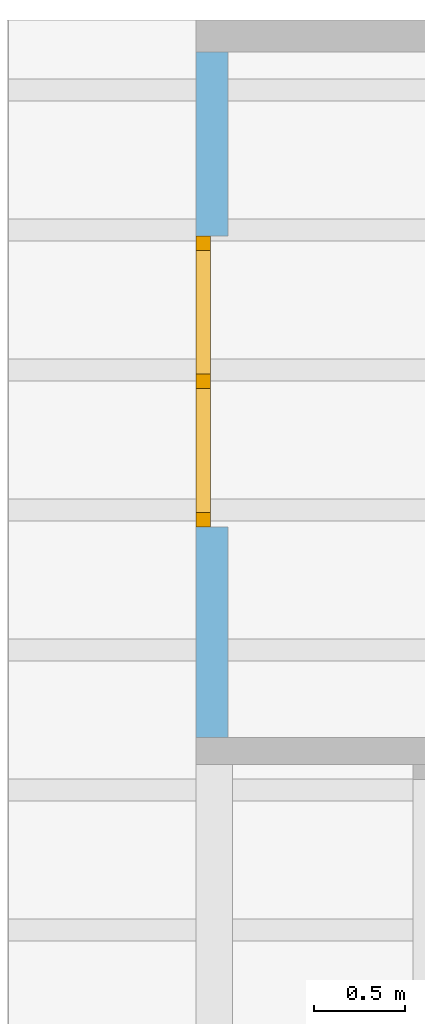
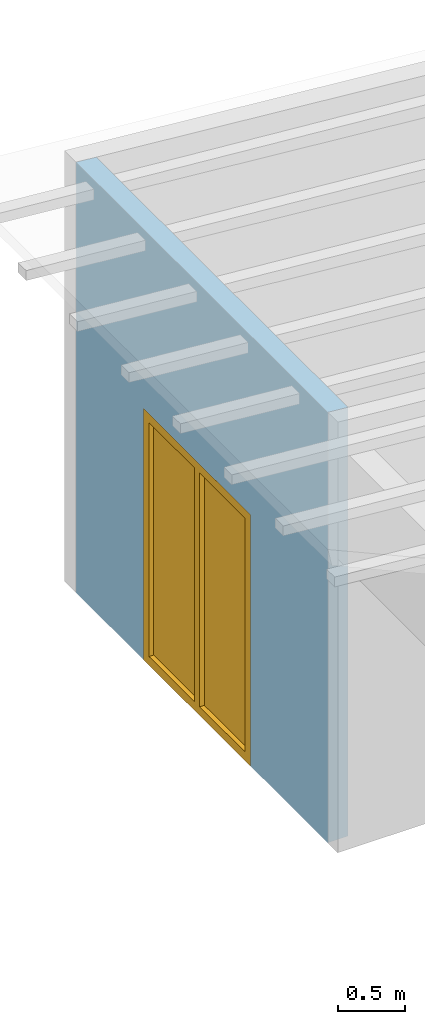
# One storey, part 12 of 13: 1 window, 1 opening, plus 1 element that does not belong to this part.
"""IFC2X3 building model written with IfcOpenShell, lengths in millimetres."""

from ifc_helpers import new_model, entity, si_unit, converted_unit, frame, frame_2d, origin, origin_with_axes, place, context, project, spatial, rectangle, extrude, clip, halfspace, faceted_brep, material, layer, layer_set, layer_usage, element, fill, save


model = new_model("IFC2X3")

# Units and contexts
model_context = context("Model", 3, precision=1e-05, world=origin())
plan_context = context("Plan", 3, precision=1e-05, world=origin())
ifc_project = project(units=[si_unit("LENGTHUNIT", "METRE", prefix="MILLI"), converted_unit("PLANEANGLEUNIT", "DEGREE", entity("IfcPlaneAngleMeasure", 0.0174532925199433), si_unit("PLANEANGLEUNIT", "RADIAN"), dimensions=[0, 0, 0, 0, 0, 0, 0]), si_unit("AREAUNIT", "SQUARE_METRE"), si_unit("VOLUMEUNIT", "CUBIC_METRE")], contexts=[model_context, plan_context])

# Building, storey
building_placement = place(None, origin())
building = spatial("IfcBuilding", under=ifc_project, at=building_placement, CompositionType="ELEMENT")
storey_placement = place(building_placement, frame((0.0, 0.0, 4770.0), z_axis=(0.0, 0.0, 1.0), x_axis=(1.0, 0.0, 0.0)))
storey = spatial("IfcBuildingStorey", under=building, at=storey_placement, Name="Geschoss", CompositionType="ELEMENT", Elevation=4770.0)

# Wall, opening, window
ifc_material_1 = material()
ifc_layer = layer(ifc_material_1, 175.0)
ifc_layer_set = layer_set([ifc_layer])
ifc_layer_usage = layer_usage(ifc_layer_set, "AXIS2", "POSITIVE", 0.0)
wall_placement = place(storey_placement, frame((21188.3517822139, 9633.4375, 0.0), z_axis=(0.0, 0.0, 1.0), x_axis=(0.0, -1.0, 0.0)))
wall = element("IfcWallStandardCase", 1, at=wall_placement, inside=storey, material=ifc_layer_usage, context=model_context, shape_type="Clipping", body=[
    clip(extrude(rectangle(XDim=3775.0, YDim=175.0, at=frame_2d((1887.5, 87.5), x_axis=(1.0, 0.0))), origin_with_axes(), (0.0, 0.0, 1.0), 3940.60829407405), halfspace(frame((0.0, 175.0, 3925.29777795701), z_axis=(0.0, -0.0871557427476597, -0.996194698091745), x_axis=(1.0, 0.0, 0.0)), True)),
])
opening_placement = place(wall_placement, frame((1015.0, 0.0, 0.0), z_axis=(0.0, 1.0, 0.0), x_axis=(0.0, 0.0, 1.0)))
opening = element("IfcOpeningElement", 2, at=opening_placement, cuts=wall, ObjectType="Opening", context=model_context, shape_type="SweptSolid", body=[
    extrude(rectangle(XDim=2300.0, YDim=1600.0, at=frame_2d((1150.0, 800.0), x_axis=(1.0, 0.0))), origin_with_axes(), (0.0, 0.0, 1.0), 175.0),
])
ifc_material_2 = material()
window_placement = place(opening_placement, frame((0.0, 0.0, 0.0), z_axis=(1.0, 0.0, 0.0), x_axis=(0.0, 1.0, 0.0)))
window = element("IfcWindow", 3, at=window_placement, inside=storey, material=ifc_material_2, Name="m", OverallHeight=2300.0, OverallWidth=1600.0, context=model_context, shape_type="Brep", body=[
    faceted_brep([(80.0000000000009, 4.37193614644116e-11, 0.0), (9.09494701772928e-13, 4.37242464457199e-11, 0.0), (9.09494701772928e-13, 4.37242464457199e-11, 2300.0), (80.0000000000009, 4.37193614644116e-11, 2300.0), (9.09494701772928e-13, 80.0000000000437, 0.0), (80.0000000000009, 80.0000000000437, 0.0), (80.0000000000009, 80.0000000000437, 2300.0), (9.09494701772928e-13, 80.0000000000437, 2300.0), (9.09494701772928e-13, 4.37242464457199e-11, 0.0), (80.0000000000009, 4.37193614644116e-11, 0.0), (80.0000000000009, 80.0000000000437, 0.0), (9.09494701772928e-13, 80.0000000000437, 0.0), (9.09494701772928e-13, 4.37242464457199e-11, 2300.0), (9.09494701772928e-13, 4.37242464457199e-11, 0.0), (9.09494701772928e-13, 80.0000000000437, 0.0), (9.09494701772928e-13, 80.0000000000437, 2300.0), (80.0000000000009, 4.37193614644116e-11, 2300.0), (9.09494701772928e-13, 4.37242464457199e-11, 2300.0), (9.09494701772928e-13, 80.0000000000437, 2300.0), (80.0000000000009, 80.0000000000437, 2300.0), (80.0000000000009, 4.37193614644116e-11, 0.0), (80.0000000000009, 4.37193614644116e-11, 2300.0), (80.0000000000009, 80.0000000000437, 2300.0), (80.0000000000009, 80.0000000000437, 0.0)], [[[0, 1, 2, 3]], [[4, 5, 6, 7]], [[8, 9, 10, 11]], [[12, 13, 14, 15]], [[16, 17, 18, 19]], [[20, 21, 22, 23]]], orient=[[False], [False], [False], [False], [False], [False]]),
    faceted_brep([(1520.0, 4.36134461878623e-11, 2300.0), (1600.0, 4.3608561206554e-11, 2300.0), (1600.0, 4.3608561206554e-11, 0.0), (1520.0, 4.36134461878623e-11, 0.0), (1600.0, 80.0000000000436, 2300.0), (1520.0, 80.0000000000436, 2300.0), (1520.0, 80.0000000000436, 0.0), (1600.0, 80.0000000000436, 0.0), (1600.0, 4.3608561206554e-11, 2300.0), (1520.0, 4.36134461878623e-11, 2300.0), (1520.0, 80.0000000000436, 2300.0), (1600.0, 80.0000000000436, 2300.0), (1600.0, 4.3608561206554e-11, 0.0), (1600.0, 4.3608561206554e-11, 2300.0), (1600.0, 80.0000000000436, 2300.0), (1600.0, 80.0000000000436, 0.0), (1520.0, 4.36134461878623e-11, 0.0), (1600.0, 4.3608561206554e-11, 0.0), (1600.0, 80.0000000000436, 0.0), (1520.0, 80.0000000000436, 0.0), (1520.0, 4.36134461878623e-11, 2300.0), (1520.0, 4.36134461878623e-11, 0.0), (1520.0, 80.0000000000436, 0.0), (1520.0, 80.0000000000436, 2300.0)], [[[0, 1, 2, 3]], [[4, 5, 6, 7]], [[8, 9, 10, 11]], [[12, 13, 14, 15]], [[16, 17, 18, 19]], [[20, 21, 22, 23]]], orient=[[False], [False], [False], [False], [False], [False]]),
    faceted_brep([(80.0000000000009, 4.37015978960176e-11, 2220.0), (80.0000000000009, 4.37015978960176e-11, 2300.0), (1520.0, 4.36134461878623e-11, 2300.0), (1520.0, 4.36134461878623e-11, 2220.0), (80.0000000000009, 80.0000000000437, 2300.0), (80.0000000000009, 80.0000000000437, 2220.0), (1520.0, 80.0000000000436, 2220.0), (1520.0, 80.0000000000436, 2300.0), (80.0000000000009, 4.37015978960176e-11, 2300.0), (80.0000000000009, 4.37015978960176e-11, 2220.0), (80.0000000000009, 80.0000000000437, 2220.0), (80.0000000000009, 80.0000000000437, 2300.0), (1520.0, 4.36134461878623e-11, 2300.0), (80.0000000000009, 4.37015978960176e-11, 2300.0), (80.0000000000009, 80.0000000000437, 2300.0), (1520.0, 80.0000000000436, 2300.0), (1520.0, 4.36134461878623e-11, 2220.0), (1520.0, 4.36134461878623e-11, 2300.0), (1520.0, 80.0000000000436, 2300.0), (1520.0, 80.0000000000436, 2220.0), (80.0000000000009, 4.37015978960176e-11, 2220.0), (1520.0, 4.36134461878623e-11, 2220.0), (1520.0, 80.0000000000436, 2220.0), (80.0000000000009, 80.0000000000437, 2220.0)], [[[0, 1, 2, 3]], [[4, 5, 6, 7]], [[8, 9, 10, 11]], [[12, 13, 14, 15]], [[16, 17, 18, 19]], [[20, 21, 22, 23]]], orient=[[False], [False], [False], [False], [False], [False]]),
    faceted_brep([(1520.0, 4.36134461878623e-11, 80.0), (1520.0, 4.36134461878623e-11, 0.0), (80.0000000000009, 4.37015978960176e-11, 0.0), (80.0000000000009, 4.37015978960176e-11, 80.0), (1520.0, 80.0000000000436, 0.0), (1520.0, 80.0000000000436, 80.0), (80.0000000000009, 80.0000000000437, 80.0), (80.0000000000009, 80.0000000000437, 0.0), (1520.0, 4.36134461878623e-11, 0.0), (1520.0, 4.36134461878623e-11, 80.0), (1520.0, 80.0000000000436, 80.0), (1520.0, 80.0000000000436, 0.0), (80.0000000000009, 4.37015978960176e-11, 0.0), (1520.0, 4.36134461878623e-11, 0.0), (1520.0, 80.0000000000436, 0.0), (80.0000000000009, 80.0000000000437, 0.0), (80.0000000000009, 4.37015978960176e-11, 80.0), (80.0000000000009, 4.37015978960176e-11, 0.0), (80.0000000000009, 80.0000000000437, 0.0), (80.0000000000009, 80.0000000000437, 80.0), (1520.0, 4.36134461878623e-11, 80.0), (80.0000000000009, 4.37015978960176e-11, 80.0), (80.0000000000009, 80.0000000000437, 80.0), (1520.0, 80.0000000000436, 80.0)], [[[0, 1, 2, 3]], [[4, 5, 6, 7]], [[8, 9, 10, 11]], [[12, 13, 14, 15]], [[16, 17, 18, 19]], [[20, 21, 22, 23]]], orient=[[False], [False], [False], [False], [False], [False]]),
    faceted_brep([(840.0, 4.36550795512858e-11, 80.0), (760.0, 4.36599645325941e-11, 80.0), (760.0, 4.36599645325941e-11, 2220.0), (840.0, 4.36550795512858e-11, 2220.0), (760.0, 80.0000000000437, 80.0), (840.0, 80.0000000000436, 80.0), (840.0, 80.0000000000436, 2220.0), (760.0, 80.0000000000437, 2220.0), (760.0, 4.36599645325941e-11, 80.0), (840.0, 4.36550795512858e-11, 80.0), (840.0, 80.0000000000436, 80.0), (760.0, 80.0000000000437, 80.0), (760.0, 4.36599645325941e-11, 2220.0), (760.0, 4.36599645325941e-11, 80.0), (760.0, 80.0000000000437, 80.0), (760.0, 80.0000000000437, 2220.0), (840.0, 4.36550795512858e-11, 2220.0), (760.0, 4.36599645325941e-11, 2220.0), (760.0, 80.0000000000437, 2220.0), (840.0, 80.0000000000436, 2220.0), (840.0, 4.36550795512858e-11, 80.0), (840.0, 4.36550795512858e-11, 2220.0), (840.0, 80.0000000000436, 2220.0), (840.0, 80.0000000000436, 80.0)], [[[0, 1, 2, 3]], [[4, 5, 6, 7]], [[8, 9, 10, 11]], [[12, 13, 14, 15]], [[16, 17, 18, 19]], [[20, 21, 22, 23]]], orient=[[False], [False], [False], [False], [False], [False]]),
    faceted_brep([(1520.0, 40.0000000000436, 2220.0), (1520.0, 40.0000000000436, 80.0), (840.0, 40.0000000000437, 80.0), (840.0, 40.0000000000437, 2220.0), (1520.0, 41.0000000000436, 2220.0), (840.0, 41.0000000000437, 2220.0), (840.0, 41.0000000000437, 80.0), (1520.0, 41.0000000000436, 80.0), (1520.0, 40.0000000000436, 2220.0), (1520.0, 41.0000000000436, 2220.0), (1520.0, 41.0000000000436, 80.0), (1520.0, 40.0000000000436, 80.0), (1520.0, 40.0000000000436, 80.0), (1520.0, 41.0000000000436, 80.0), (840.0, 41.0000000000437, 80.0), (840.0, 40.0000000000437, 80.0), (840.0, 40.0000000000437, 80.0), (840.0, 41.0000000000437, 80.0), (840.0, 41.0000000000437, 2220.0), (840.0, 40.0000000000437, 2220.0), (840.0, 40.0000000000437, 2220.0), (840.0, 41.0000000000437, 2220.0), (1520.0, 41.0000000000436, 2220.0), (1520.0, 40.0000000000436, 2220.0)], [[[0, 1, 2, 3]], [[4, 5, 6, 7]], [[8, 9, 10, 11]], [[12, 13, 14, 15]], [[16, 17, 18, 19]], [[20, 21, 22, 23]]], orient=[[False], [False], [False], [False], [False], [False]]),
    faceted_brep([(80.0000000000009, 40.0000000000437, 80.0), (80.0000000000009, 40.0000000000437, 2220.0), (760.0, 40.0000000000437, 2220.0), (760.0, 40.0000000000437, 80.0), (80.0000000000009, 41.0000000000437, 80.0), (760.0, 41.0000000000437, 80.0), (760.0, 41.0000000000437, 2220.0), (80.0000000000009, 41.0000000000437, 2220.0), (80.0000000000009, 40.0000000000437, 80.0), (80.0000000000009, 41.0000000000437, 80.0), (80.0000000000009, 41.0000000000437, 2220.0), (80.0000000000009, 40.0000000000437, 2220.0), (80.0000000000009, 40.0000000000437, 2220.0), (80.0000000000009, 41.0000000000437, 2220.0), (760.0, 41.0000000000437, 2220.0), (760.0, 40.0000000000437, 2220.0), (760.0, 40.0000000000437, 2220.0), (760.0, 41.0000000000437, 2220.0), (760.0, 41.0000000000437, 80.0), (760.0, 40.0000000000437, 80.0), (760.0, 40.0000000000437, 80.0), (760.0, 41.0000000000437, 80.0), (80.0000000000009, 41.0000000000437, 80.0), (80.0000000000009, 40.0000000000437, 80.0)], [[[0, 1, 2, 3]], [[4, 5, 6, 7]], [[8, 9, 10, 11]], [[12, 13, 14, 15]], [[16, 17, 18, 19]], [[20, 21, 22, 23]]], orient=[[False], [False], [False], [False], [False], [False]]),
])
fill(opening, window)

save(model, "model.ifc")
